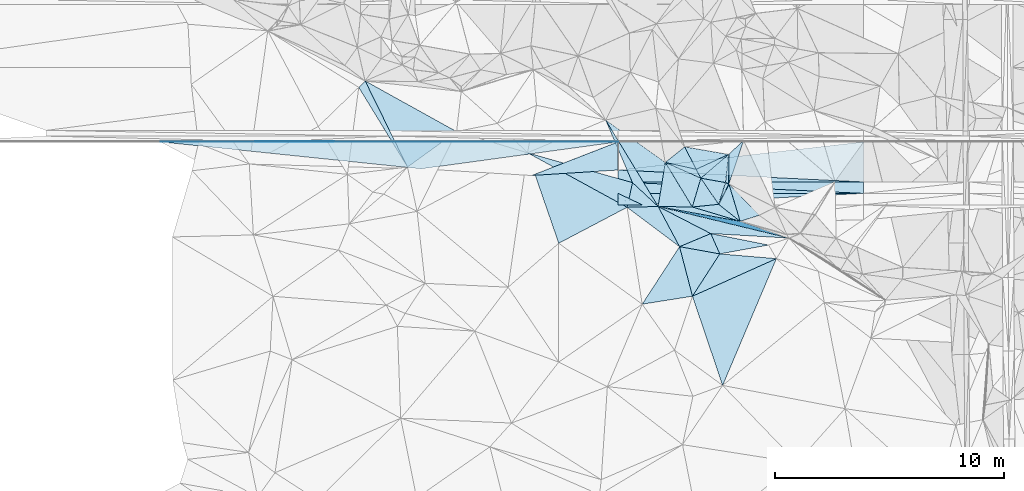
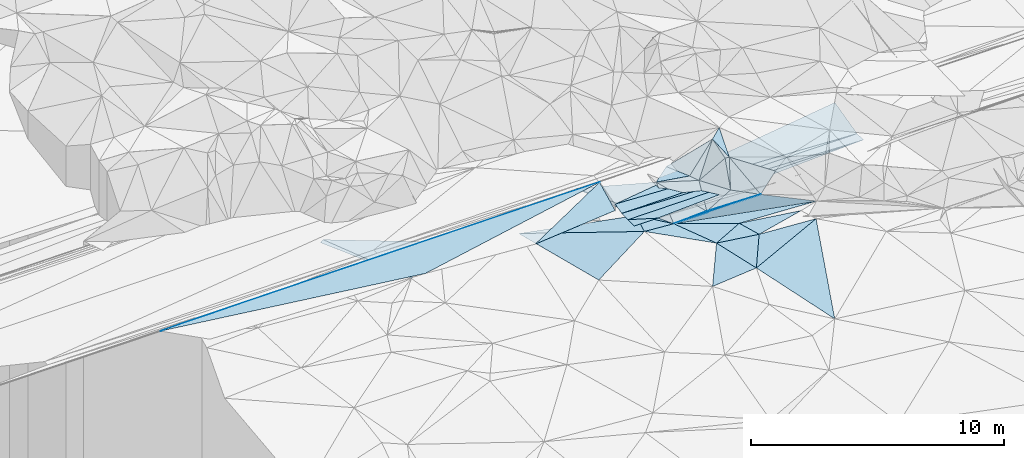
# One storey, part 47 of 275: 50 plates.
"""IFC2X3 building model written with IfcOpenShell, lengths in millimetres."""

from ifc_helpers import new_model, si_unit, frame, origin_with_axes, place, context, subcontext, project, spatial, polyline, outline, extrude, material, type_object, element, save


model = new_model("IFC2X3")

# Units and contexts
model_context = context("Model", 3, precision=1e-05, world=origin_with_axes())
body_context = subcontext(model_context, "Body", "Model", "MODEL_VIEW")
ifc_project = project(units=[si_unit("LENGTHUNIT", "METRE", prefix="MILLI"), si_unit("AREAUNIT", "SQUARE_METRE"), si_unit("VOLUMEUNIT", "CUBIC_METRE"), si_unit("MASSUNIT", "GRAM", prefix="KILO"), si_unit("TIMEUNIT", "SECOND"), si_unit("PLANEANGLEUNIT", "RADIAN"), si_unit("SOLIDANGLEUNIT", "STERADIAN"), si_unit("THERMODYNAMICTEMPERATUREUNIT", "DEGREE_CELSIUS"), si_unit("LUMINOUSINTENSITYUNIT", "LUMEN")], contexts=[model_context])

# Site, building, storey
site_placement = place(None, origin_with_axes())
site = spatial("IfcSite", under=ifc_project, at=site_placement, CompositionType="ELEMENT")
building_placement = place(site_placement, origin_with_axes())
building = spatial("IfcBuilding", under=site, at=building_placement, Name="Undefined", CompositionType="ELEMENT")
storey_placement = place(building_placement, origin_with_axes())
storey = spatial("IfcBuildingStorey", under=building, at=storey_placement, Name="Undefined", CompositionType="ELEMENT", Elevation=0.0)

# Plates
ifc_material = material()
plate_type_1 = type_object("IfcPlateType", PredefinedType="NOTDEFINED")
for number, where, z_axis, x_axis, name in (
    (1, (-135830.614985096, 60064.7002229787, 48829.0156310434), (0.00831814909004302, 0.0498972698790332, -0.998719715863432), (0.999964926595862, -0.00139059996523865, 0.00825904412565631), "00_PR"),
    (2, (-135830.614985096, 60064.7002229787, 48829.0156310434), (0.00831814909004302, 0.0498972698790332, -0.998719715863432), (0.999964926595862, -0.00139059996523865, 0.00825904412565631), "00_PR"),
    (3, (-135830.614985096, 60064.7002229787, 48829.0156310434), (0.00831814909004302, 0.0498972698790332, -0.998719715863432), (0.999964926595862, -0.00139059996523865, 0.00825904412565631), "00_PR"),
):
    element("IfcPlate", number, at=place(storey_placement, frame(where, z_axis=z_axis, x_axis=x_axis)), inside=storey, type_object=plate_type_1, material=ifc_material, Name=name, context=body_context, shape_type="SweptSolid", body=[
        extrude(outline(polyline([(0.0, 0.0), (15000.525390625, -6.48433342576027e-08), (-5000.150390625, 26.7003498077393), (0.0, 0.0)])), frame((-8.85201319254618e-08, 2.18876761149539e-07, -0.5000001331573), z_axis=(0.0, 0.0, 1.0), x_axis=(1.0, 0.0, 0.0)), (0.0, 0.0, 1.0), 1.0),
    ])
plate_type_2 = type_object("IfcPlateType", PredefinedType="NOTDEFINED")
plate_1_placement = place(storey_placement, frame((-115496.287308976, 56570.7317916144, 48609.6284639747), z_axis=(0.369579118657339, 0.557927886669343, -0.743052991602311), x_axis=(-0.782548067438589, 0.618072932079642, 0.0748623588901896)))
element("IfcPlate", 4, at=plate_1_placement, inside=storey, type_object=plate_type_2, material=ifc_material, Name="00", context=body_context, shape_type="SweptSolid", body=[
    extrude(outline(polyline([(0.0, 0.0), (1202.20629882813, -6.49015419185162e-09), (1465.638671875, 1308.62658691406), (0.0, 0.0)])), frame((-8.85201319254618e-08, 2.18876761149539e-07, -0.5000001331573), z_axis=(0.0, 0.0, 1.0), x_axis=(1.0, 0.0, 0.0)), (0.0, 0.0, 1.0), 1.0),
])
plate_type_3 = type_object("IfcPlateType", PredefinedType="NOTDEFINED")
plate_2_placement = place(storey_placement, frame((-119776.668970468, 57293.7547584565, 48524.1770099493), z_axis=(0.00832513340286068, 7.26597750999418e-06, -0.999965345450046), x_axis=(-0.903459853066548, 0.428606771995645, -0.0075185701064053)))
element("IfcPlate", 5, at=plate_2_placement, inside=storey, type_object=plate_type_3, material=ifc_material, Name="00_PR", context=body_context, shape_type="SweptSolid", body=[
    extrude(outline(polyline([(0.0, 0.0), (1166.71130371094, -6.47207798465388e-09), (-8521.5361328125, 4595.3232421875), (0.0, 0.0)])), frame((-8.85201319254618e-08, 2.18876761149539e-07, -0.5000001331573), z_axis=(0.0, 0.0, 1.0), x_axis=(1.0, 0.0, 0.0)), (0.0, 0.0, 1.0), 1.0),
])
plate_3_placement = place(storey_placement, frame((-120830.745792086, 57793.8151177411, 48515.4050098334), z_axis=(0.00832145934312362, -4.76784125253999e-07, -0.999965376057678), x_axis=(0.903459853075968, -0.428606771993251, 0.00751856911092421)))
element("IfcPlate", 6, at=plate_3_placement, inside=storey, type_object=plate_type_3, material=ifc_material, Name="00_PR", context=body_context, shape_type="SweptSolid", body=[
    extrude(outline(polyline([(0.0, 0.0), (1166.71130371094, -6.47207798465388e-09), (214.27751159668, 451.757843017578), (0.0, 0.0)])), frame((-8.85201319254618e-08, 2.18876761149539e-07, -0.5000001331573), z_axis=(0.0, 0.0, 1.0), x_axis=(1.0, 0.0, 0.0)), (0.0, 0.0, 1.0), 1.0),
])
for number, where, z_axis, x_axis, name in (
    (7, (-110108.284694637, 57793.2000674163, 48604.6740113437), (0.00832513166356312, -8.47678224280591e-06, -0.999965345454996), (-0.999965344853481, 5.72919765649429e-05, -0.00832501109232228), "00_PR"),
    (8, (-120830.717145383, 58293.8151223434, 48515.401009975), (0.00832550512650313, -4.76525014343269e-07, -0.999965342381505), (0.999965340787191, -5.73519775278889e-05, 0.0083254990906575), "00_PR"),
):
    element("IfcPlate", number, at=place(storey_placement, frame(where, z_axis=z_axis, x_axis=x_axis)), inside=storey, type_object=plate_type_3, material=ifc_material, Name=name, context=body_context, shape_type="SweptSolid", body=[
        extrude(outline(polyline([(0.0, 0.0), (10722.8330078125, 1.17288436740637e-08), (10722.8330078125, 500.0), (0.0, 0.0)])), frame((-8.85201319254618e-08, 2.18876761149539e-07, -0.5000001331573), z_axis=(0.0, 0.0, 1.0), x_axis=(1.0, 0.0, 0.0)), (0.0, 0.0, 1.0), 1.0),
    ])
for number, where, z_axis, x_axis, name in (
    (9, (-120830.745792086, 57793.8151177411, 48515.4050098334), (0.00832145934312362, -4.76784125253999e-07, -0.999965376057678), (0.903459853075968, -0.428606771993251, 0.00751856911092421), "00_PR"),
    (10, (-120830.745792086, 57793.8151177411, 48515.4050098334), (0.00832145934312362, -4.76784125253999e-07, -0.999965376057678), (0.903459853075968, -0.428606771993251, 0.00751856911092421), "00_PR"),
):
    element("IfcPlate", number, at=place(storey_placement, frame(where, z_axis=z_axis, x_axis=x_axis)), inside=storey, type_object=plate_type_3, material=ifc_material, Name=name, context=body_context, shape_type="SweptSolid", body=[
        extrude(outline(polyline([(0.0, 0.0), (1166.71130371094, -6.47207798465388e-09), (214.27751159668, 451.757843017578), (0.0, 0.0)])), frame((-8.85201319254618e-08, 2.18876761149539e-07, -0.5000001331573), z_axis=(0.0, 0.0, 1.0), x_axis=(1.0, 0.0, 0.0)), (0.0, 0.0, 1.0), 1.0),
    ])
plate_type_4 = type_object("IfcPlateType", PredefinedType="NOTDEFINED")
plate_4_placement = place(storey_placement, frame((-117420.948933111, 58846.7037948229, 48789.5661166067), z_axis=(0.431720832488177, 0.246223203070073, -0.867750688311815), x_axis=(-0.453388963247249, 0.890896965022592, 0.0272221549315876)))
element("IfcPlate", 11, at=plate_4_placement, inside=storey, type_object=plate_type_4, material=ifc_material, Name="00", context=body_context, shape_type="SweptSolid", body=[
    extrude(outline(polyline([(0.0, 0.0), (1102.04357910156, -3.63797880709171e-10), (-40.7424926757813, 1795.67260742188), (0.0, 0.0)])), frame((-8.85201319254618e-08, 2.18876761149539e-07, -0.5000001331573), z_axis=(0.0, 0.0, 1.0), x_axis=(1.0, 0.0, 0.0)), (0.0, 0.0, 1.0), 1.0),
])
plate_type_5 = type_object("IfcPlateType", PredefinedType="NOTDEFINED")
plate_5_placement = place(storey_placement, frame((-119081.786190198, 57221.0828771322, 48055.5627136048), z_axis=(0.0475193731730048, -0.482618434945434, -0.874540653957302), x_axis=(0.99790219875624, -0.0156006788333907, 0.0628316841840036)))
element("IfcPlate", 12, at=plate_5_placement, inside=storey, type_object=plate_type_5, material=ifc_material, Name="00", context=body_context, shape_type="SweptSolid", body=[
    extrude(outline(polyline([(0.0, 0.0), (1496.060546875, -9.93895810097456e-09), (3622.779296875, 678.724609375), (0.0, 0.0)])), frame((-8.85201319254618e-08, 2.18876761149539e-07, -0.5000001331573), z_axis=(0.0, 0.0, 1.0), x_axis=(1.0, 0.0, 0.0)), (0.0, 0.0, 1.0), 1.0),
])
plate_type_6 = type_object("IfcPlateType", PredefinedType="NOTDEFINED")
for number, where, z_axis, x_axis, name in (
    (13, (-124610.772724842, 58574.9100282311, 48186.809792077), (0.0074718395491489, 0.447203045414868, -0.894401256587567), (0.915882799607356, 0.355950908885779, 0.185627713035471), "00_PR"),
    (14, (-124610.772724842, 58574.9100282311, 48186.809792077), (0.0074718395491489, 0.447203045414868, -0.894401256587567), (0.915882799607356, 0.355950908885779, 0.185627713035471), "00_PR"),
    (15, (-124610.772724842, 58574.9100282311, 48186.809792077), (0.0074718395491489, 0.447203045414868, -0.894401256587567), (0.915882799607356, 0.355950908885779, 0.185627713035471), "00_PR"),
):
    element("IfcPlate", number, at=place(storey_placement, frame(where, z_axis=z_axis, x_axis=x_axis)), inside=storey, type_object=plate_type_6, material=ifc_material, Name=name, context=body_context, shape_type="SweptSolid", body=[
        extrude(outline(polyline([(0.0, 0.0), (4127.33642578125, 1.97178451344371e-08), (3575.8720703125, 1258.1845703125), (0.0, 0.0)])), frame((-8.85201319254618e-08, 2.18876761149539e-07, -0.5000001331573), z_axis=(0.0, 0.0, 1.0), x_axis=(1.0, 0.0, 0.0)), (0.0, 0.0, 1.0), 1.0),
    ])
plate_type_7 = type_object("IfcPlateType", PredefinedType="NOTDEFINED")
for number, where, z_axis, x_axis, name in (
    (16, (-120830.616385825, 60044.0391399351, 48952.9577921263), (0.0074723662007596, 0.44720202102918, -0.89440176438264), (-0.987924691395056, -0.135118973085206, -0.0758133711450937), "00_PR"),
    (17, (-120830.616385825, 60044.0391399351, 48952.9577921263), (0.0074723662007596, 0.44720202102918, -0.89440176438264), (-0.987924691395056, -0.135118973085206, -0.0758133711450937), "00_PR"),
    (18, (-120830.616385825, 60044.0391399351, 48952.9577921263), (0.0074723662007596, 0.44720202102918, -0.89440176438264), (-0.987924691395056, -0.135118973085206, -0.0758133711450937), "00_PR"),
):
    element("IfcPlate", number, at=place(storey_placement, frame(where, z_axis=z_axis, x_axis=x_axis)), inside=storey, type_object=plate_type_7, material=ifc_material, Name=name, context=body_context, shape_type="SweptSolid", body=[
        extrude(outline(polyline([(0.0, 0.0), (8719.609375, -2.08528945222497e-08), (19770.962890625, 3022.70361328125), (0.0, 0.0)])), frame((-8.85201319254618e-08, 2.18876761149539e-07, -0.5000001331573), z_axis=(0.0, 0.0, 1.0), x_axis=(1.0, 0.0, 0.0)), (0.0, 0.0, 1.0), 1.0),
    ])
plate_type_8 = type_object("IfcPlateType", PredefinedType="NOTDEFINED")
plate_6_placement = place(storey_placement, frame((-116779.892308437, 56035.932033889, 47989.5063971558), z_axis=(0.0282640599836552, 0.157148972542675, -0.98717037199362), x_axis=(0.400760479645804, -0.906502308759819, -0.132832985990617)))
element("IfcPlate", 19, at=plate_6_placement, inside=storey, type_object=plate_type_8, material=ifc_material, Name="00", context=body_context, shape_type="SweptSolid", body=[
    extrude(outline(polyline([(0.0, 0.0), (978.672546386719, 1.92085281014442e-09), (-12.4658651351929, 1485.94909667969), (0.0, 0.0)])), frame((-8.85201319254618e-08, 2.18876761149539e-07, -0.5000001331573), z_axis=(0.0, 0.0, 1.0), x_axis=(1.0, 0.0, 0.0)), (0.0, 0.0, 1.0), 1.0),
])
plate_type_9 = type_object("IfcPlateType", PredefinedType="NOTDEFINED")
plate_7_placement = place(storey_placement, frame((-110108.256159867, 58293.3213430819, 48604.688939679), z_axis=(0.00809083870061443, 0.242535022060941, -0.970108912134622), x_axis=(-0.999965344853481, 5.72919765649429e-05, -0.00832501109232228)))
element("IfcPlate", 20, at=plate_7_placement, inside=storey, type_object=plate_type_9, material=ifc_material, Name="00_PR", context=body_context, shape_type="SweptSolid", body=[
    extrude(outline(polyline([(0.0, 0.0), (10722.8330078125, 1.17288436740637e-08), (10721.748046875, 537.341918945313), (0.0, 0.0)])), frame((-8.85201319254618e-08, 2.18876761149539e-07, -0.5000001331573), z_axis=(0.0, 0.0, 1.0), x_axis=(1.0, 0.0, 0.0)), (0.0, 0.0, 1.0), 1.0),
])
plate_type_10 = type_object("IfcPlateType", PredefinedType="NOTDEFINED")
plate_8_placement = place(storey_placement, frame((-120830.687312707, 58815.2346338975, 48645.7449369341), z_axis=(0.0080904527200821, 0.242527248972756, -0.970110858655077), x_axis=(0.992835304323533, 0.113712686067626, 0.0367080851595779)))
element("IfcPlate", 21, at=plate_8_placement, inside=storey, type_object=plate_type_10, material=ifc_material, Name="00_PR", context=body_context, shape_type="SweptSolid", body=[
    extrude(outline(polyline([(0.0, 0.0), (10799.9091796875, -4.02069417759776e-08), (10584.7529296875, 1790.98132324219), (0.0, 0.0)])), frame((-8.85201319254618e-08, 2.18876761149539e-07, -0.5000001331573), z_axis=(0.0, 0.0, 1.0), x_axis=(1.0, 0.0, 0.0)), (0.0, 0.0, 1.0), 1.0),
])
plate_type_11 = type_object("IfcPlateType", PredefinedType="NOTDEFINED")
plate_9_placement = place(storey_placement, frame((-118145.677767333, 55464.8757415117, 47859.5006336671), z_axis=(-0.0449011696740856, 0.0251768616614847, -0.998674126328893), x_axis=(0.251875103580906, -0.967100851608262, -0.0357053919553195)))
element("IfcPlate", 22, at=plate_9_placement, inside=storey, type_object=plate_type_11, material=ifc_material, Name="00", context=body_context, shape_type="SweptSolid", body=[
    extrude(outline(polyline([(0.0, 0.0), (2240.55786132813, -1.46974343806505e-09), (2020.56811523438, 2215.19848632813), (0.0, 0.0)])), frame((-8.85201319254618e-08, 2.18876761149539e-07, -0.5000001331573), z_axis=(0.0, 0.0, 1.0), x_axis=(1.0, 0.0, 0.0)), (0.0, 0.0, 1.0), 1.0),
])
plate_type_12 = type_object("IfcPlateType", PredefinedType="NOTDEFINED")
plate_10_placement = place(storey_placement, frame((-116002.266986753, 59495.8079570777, 49679.5690904599), z_axis=(0.39502987458071, 0.318240899055146, -0.861785430578471), x_axis=(-0.654566115018615, -0.560705981335617, -0.507101571249686)))
element("IfcPlate", 23, at=plate_10_placement, inside=storey, type_object=plate_type_12, material=ifc_material, Name="00", context=body_context, shape_type="SweptSolid", body=[
    extrude(outline(polyline([(0.0, 0.0), (1853.67199707031, 2.5029294192791e-09), (1743.88989257813, 430.055694580078), (0.0, 0.0)])), frame((-8.85201319254618e-08, 2.18876761149539e-07, -0.5000001331573), z_axis=(0.0, 0.0, 1.0), x_axis=(1.0, 0.0, 0.0)), (0.0, 0.0, 1.0), 1.0),
])
plate_type_13 = type_object("IfcPlateType", PredefinedType="NOTDEFINED")
plate_11_placement = place(storey_placement, frame((-120437.010643785, 57185.3307943349, 48179.5030814484), z_axis=(-0.09257169403787, 0.0615576643962565, -0.993801356115515), x_axis=(0.995490997743403, 0.0264632216691322, -0.0910899078423896)))
element("IfcPlate", 24, at=plate_11_placement, inside=storey, type_object=plate_type_13, material=ifc_material, Name="00", context=body_context, shape_type="SweptSolid", body=[
    extrude(outline(polyline([(0.0, 0.0), (1361.29235839844, -1.38243194669485e-09), (2264.59790039063, 1784.37548828125), (0.0, 0.0)])), frame((-8.85201319254618e-08, 2.18876761149539e-07, -0.5000001331573), z_axis=(0.0, 0.0, 1.0), x_axis=(1.0, 0.0, 0.0)), (0.0, 0.0, 1.0), 1.0),
])
plate_type_14 = type_object("IfcPlateType", PredefinedType="NOTDEFINED")
plate_12_placement = place(storey_placement, frame((-116136.659847027, 58266.5878108403, 49549.6312453976), z_axis=(0.426882667840605, 0.523330572044719, -0.73749325438314), x_axis=(0.889623177160462, -0.389398382859552, 0.2386199951498)))
element("IfcPlate", 25, at=plate_12_placement, inside=storey, type_object=plate_type_14, material=ifc_material, Name="00", context=body_context, shape_type="SweptSolid", body=[
    extrude(outline(polyline([(0.0, 0.0), (167.63053894043, 6.18456397205591e-10), (-99.0272979736328, 1307.97314453125), (0.0, 0.0)])), frame((-8.85201319254618e-08, 2.18876761149539e-07, -0.5000001331573), z_axis=(0.0, 0.0, 1.0), x_axis=(1.0, 0.0, 0.0)), (0.0, 0.0, 1.0), 1.0),
])
plate_type_15 = type_object("IfcPlateType", PredefinedType="NOTDEFINED")
plate_13_placement = place(storey_placement, frame((-132169.328461947, 62429.2057095855, 48569.5282414469), z_axis=(-0.317153133267479, -0.0964946855527176, -0.943452524358647), x_axis=(0.675608799542987, 0.675157178374258, -0.296168084826495)))
element("IfcPlate", 26, at=plate_13_placement, inside=storey, type_object=plate_type_15, material=ifc_material, Name="00", context=body_context, shape_type="SweptSolid", body=[
    extrude(outline(polyline([(0.0, 0.0), (415.304718017578, 4.77302819490433e-09), (-806.80517578125, 4021.53759765625), (0.0, 0.0)])), frame((-8.85201319254618e-08, 2.18876761149539e-07, -0.5000001331573), z_axis=(0.0, 0.0, 1.0), x_axis=(1.0, 0.0, 0.0)), (0.0, 0.0, 1.0), 1.0),
])
plate_type_16 = type_object("IfcPlateType", PredefinedType="NOTDEFINED")
plate_14_placement = place(storey_placement, frame((-117215.51422111, 58456.2931064135, 48739.6009856864), z_axis=(0.602357626799438, 0.0185299595391645, -0.798011234279334), x_axis=(0.654566115015034, 0.560705981347095, 0.507101571241617)))
element("IfcPlate", 27, at=plate_14_placement, inside=storey, type_object=plate_type_16, material=ifc_material, Name="00", context=body_context, shape_type="SweptSolid", body=[
    extrude(outline(polyline([(0.0, 0.0), (1853.67199707031, 2.5029294192791e-09), (1010.48077392578, 913.908386230469), (0.0, 0.0)])), frame((-8.85201319254618e-08, 2.18876761149539e-07, -0.5000001331573), z_axis=(0.0, 0.0, 1.0), x_axis=(1.0, 0.0, 0.0)), (0.0, 0.0, 1.0), 1.0),
])
plate_type_17 = type_object("IfcPlateType", PredefinedType="NOTDEFINED")
plate_15_placement = place(storey_placement, frame((-115987.543498909, 58201.3298713433, 49589.6372664755), z_axis=(0.403551745914306, 0.557574890465013, -0.725435200340075), x_axis=(0.687979215344768, -0.707610294097635, -0.161159147865258)))
element("IfcPlate", 28, at=plate_15_placement, inside=storey, type_object=plate_type_17, material=ifc_material, Name="00", context=body_context, shape_type="SweptSolid", body=[
    extrude(outline(polyline([(0.0, 0.0), (1923.564453125, -1.14450813271105e-08), (1649.74975585938, 1067.20458984375), (0.0, 0.0)])), frame((-8.85201319254618e-08, 2.18876761149539e-07, -0.5000001331573), z_axis=(0.0, 0.0, 1.0), x_axis=(1.0, 0.0, 0.0)), (0.0, 0.0, 1.0), 1.0),
])
plate_type_18 = type_object("IfcPlateType", PredefinedType="NOTDEFINED")
plate_16_placement = place(storey_placement, frame((-116387.671054048, 55148.7664768484, 47859.5072283944), z_axis=(0.0441410186254733, 0.163921193080716, -0.985485369213415), x_axis=(-0.400760479635588, 0.9065023087724, 0.132832985935581)))
element("IfcPlate", 29, at=plate_16_placement, inside=storey, type_object=plate_type_18, material=ifc_material, Name="00", context=body_context, shape_type="SweptSolid", body=[
    extrude(outline(polyline([(0.0, 0.0), (978.672546386719, 1.92085281014442e-09), (-484.227325439453, 2122.10375976563), (0.0, 0.0)])), frame((-8.85201319254618e-08, 2.18876761149539e-07, -0.5000001331573), z_axis=(0.0, 0.0, 1.0), x_axis=(1.0, 0.0, 0.0)), (0.0, 0.0, 1.0), 1.0),
])
plate_type_19 = type_object("IfcPlateType", PredefinedType="NOTDEFINED")
plate_17_placement = place(storey_placement, frame((-118145.635659057, 55464.9288958938, 47859.504701647), z_axis=(0.0393139198775856, 0.131485636948031, -0.990538208743221), x_axis=(-0.468079857684008, 0.878235243855961, 0.0980005269362342)))
element("IfcPlate", 30, at=plate_17_placement, inside=storey, type_object=plate_type_19, material=ifc_material, Name="00", context=body_context, shape_type="SweptSolid", body=[
    extrude(outline(polyline([(0.0, 0.0), (1999.9892578125, -8.71659722179174e-09), (-125.075675964355, 1480.72827148438), (0.0, 0.0)])), frame((-8.85201319254618e-08, 2.18876761149539e-07, -0.5000001331573), z_axis=(0.0, 0.0, 1.0), x_axis=(1.0, 0.0, 0.0)), (0.0, 0.0, 1.0), 1.0),
])
plate_type_20 = type_object("IfcPlateType", PredefinedType="NOTDEFINED")
plate_18_placement = place(storey_placement, frame((-117215.795197694, 58456.3577652648, 48739.5058996514), z_axis=(0.0403983651372587, 0.147849020110908, -0.988184516852233), x_axis=(-0.91320437258695, 0.406821718584614, 0.0235342978636645)))
element("IfcPlate", 31, at=plate_18_placement, inside=storey, type_object=plate_type_20, material=ifc_material, Name="00", context=body_context, shape_type="SweptSolid", body=[
    extrude(outline(polyline([(0.0, 0.0), (1699.64697265625, -8.90213414095342e-09), (347.483917236328, 276.142944335938), (0.0, 0.0)])), frame((-8.85201319254618e-08, 2.18876761149539e-07, -0.5000001331573), z_axis=(0.0, 0.0, 1.0), x_axis=(1.0, 0.0, 0.0)), (0.0, 0.0, 1.0), 1.0),
])
plate_type_21 = type_object("IfcPlateType", PredefinedType="NOTDEFINED")
plate_19_placement = place(storey_placement, frame((-116002.321107045, 59495.6836781537, 49679.5222625761), z_axis=(0.286780182758937, 0.0696837789164654, -0.955458684471847), x_axis=(0.011341625215273, -0.997528068826549, -0.0693478149666773)))
element("IfcPlate", 32, at=plate_19_placement, inside=storey, type_object=plate_type_21, material=ifc_material, Name="00", context=body_context, shape_type="SweptSolid", body=[
    extrude(outline(polyline([(0.0, 0.0), (1297.80578613281, -9.02218744158745e-10), (1233.77465820313, 154.919372558594), (0.0, 0.0)])), frame((-8.85201319254618e-08, 2.18876761149539e-07, -0.5000001331573), z_axis=(0.0, 0.0, 1.0), x_axis=(1.0, 0.0, 0.0)), (0.0, 0.0, 1.0), 1.0),
])
plate_type_22 = type_object("IfcPlateType", PredefinedType="NOTDEFINED")
plate_20_placement = place(storey_placement, frame((-115987.806377234, 58201.0848073332, 49589.5048871619), z_axis=(-0.122213837797875, 0.0674494753066479, -0.990209243610446), x_axis=(-0.0113416252167756, 0.997528068757604, 0.0693478159581554)))
element("IfcPlate", 33, at=plate_20_placement, inside=storey, type_object=plate_type_22, material=ifc_material, Name="00", context=body_context, shape_type="SweptSolid", body=[
    extrude(outline(polyline([(0.0, 0.0), (1297.80578613281, -9.02218744158745e-10), (1894.96752929688, 672.010314941406), (0.0, 0.0)])), frame((-8.85201319254618e-08, 2.18876761149539e-07, -0.5000001331573), z_axis=(0.0, 0.0, 1.0), x_axis=(1.0, 0.0, 0.0)), (0.0, 0.0, 1.0), 1.0),
])
plate_type_23 = type_object("IfcPlateType", PredefinedType="NOTDEFINED")
plate_21_placement = place(storey_placement, frame((-116436.961339623, 57313.7169726025, 48699.6570170575), z_axis=(0.589957034554261, 0.425938900220367, -0.68594952486244), x_axis=(-0.562800722178987, 0.826086720880697, 0.0289149909110858)))
element("IfcPlate", 34, at=plate_21_placement, inside=storey, type_object=plate_type_23, material=ifc_material, Name="00", context=body_context, shape_type="SweptSolid", body=[
    extrude(outline(polyline([(0.0, 0.0), (1383.36547851563, 2.66300048679113e-09), (642.635681152344, 1143.51184082031), (0.0, 0.0)])), frame((-8.85201319254618e-08, 2.18876761149539e-07, -0.5000001331573), z_axis=(0.0, 0.0, 1.0), x_axis=(1.0, 0.0, 0.0)), (0.0, 0.0, 1.0), 1.0),
])
plate_type_24 = type_object("IfcPlateType", PredefinedType="NOTDEFINED")
plate_22_placement = place(storey_placement, frame((-117215.741675934, 58456.4757017853, 48739.5441906565), z_axis=(0.147449970454932, 0.383720556535655, -0.911601360631283), x_axis=(-0.25926573382735, -0.874451689349122, -0.410018929145268)))
element("IfcPlate", 35, at=plate_22_placement, inside=storey, type_object=plate_type_24, material=ifc_material, Name="00", context=body_context, shape_type="SweptSolid", body=[
    extrude(outline(polyline([(0.0, 0.0), (1438.9580078125, 5.96628524363041e-09), (-218.630432128906, 1685.52685546875), (0.0, 0.0)])), frame((-8.85201319254618e-08, 2.18876761149539e-07, -0.5000001331573), z_axis=(0.0, 0.0, 1.0), x_axis=(1.0, 0.0, 0.0)), (0.0, 0.0, 1.0), 1.0),
])
plate_type_25 = type_object("IfcPlateType", PredefinedType="NOTDEFINED")
plate_23_placement = place(storey_placement, frame((-119081.626354986, 57221.4612918529, 48055.5555857234), z_axis=(0.367180894216145, 0.274215321150333, -0.888810524560242), x_axis=(-0.518404252243932, 0.853717542959993, 0.0492279199008323)))
element("IfcPlate", 36, at=plate_23_placement, inside=storey, type_object=plate_type_25, material=ifc_material, Name="00", context=body_context, shape_type="SweptSolid", body=[
    extrude(outline(polyline([(0.0, 0.0), (4428.38134765625, 9.80071490630507e-09), (1517.54235839844, 1425.06921386719), (0.0, 0.0)])), frame((-8.85201319254618e-08, 2.18876761149539e-07, -0.5000001331573), z_axis=(0.0, 0.0, 1.0), x_axis=(1.0, 0.0, 0.0)), (0.0, 0.0, 1.0), 1.0),
])
plate_type_26 = type_object("IfcPlateType", PredefinedType="NOTDEFINED")
plate_24_placement = place(storey_placement, frame((-116437.062520853, 57313.6513234433, 48699.5632542136), z_axis=(0.387600438391242, 0.294640056863977, -0.873471886811539), x_axis=(-0.89869797129302, -0.0901477812315407, -0.429203138307306)))
element("IfcPlate", 37, at=plate_24_placement, inside=storey, type_object=plate_type_26, material=ifc_material, Name="00", context=body_context, shape_type="SweptSolid", body=[
    extrude(outline(polyline([(0.0, 0.0), (1281.44445800781, -2.19733919948339e-09), (579.502258300781, 1256.1357421875), (0.0, 0.0)])), frame((-8.85201319254618e-08, 2.18876761149539e-07, -0.5000001331573), z_axis=(0.0, 0.0, 1.0), x_axis=(1.0, 0.0, 0.0)), (0.0, 0.0, 1.0), 1.0),
])
plate_type_27 = type_object("IfcPlateType", PredefinedType="NOTDEFINED")
plate_25_placement = place(storey_placement, frame((-115496.308100146, 56570.7085722303, 48609.6028712755), z_axis=(0.328002708686716, 0.511485894838055, -0.794226921273695), x_axis=(-0.937295215871749, 0.281102137797462, -0.206056464178217)))
element("IfcPlate", 38, at=plate_25_placement, inside=storey, type_object=plate_type_27, material=ifc_material, Name="00", context=body_context, shape_type="SweptSolid", body=[
    extrude(outline(polyline([(0.0, 0.0), (2232.39770507813, -6.34463503956795e-09), (1072.12072753906, 543.927490234375), (0.0, 0.0)])), frame((-8.85201319254618e-08, 2.18876761149539e-07, -0.5000001331573), z_axis=(0.0, 0.0, 1.0), x_axis=(1.0, 0.0, 0.0)), (0.0, 0.0, 1.0), 1.0),
])
plate_type_28 = type_object("IfcPlateType", PredefinedType="NOTDEFINED")
plate_26_placement = place(storey_placement, frame((-115496.363234401, 56570.9120949491, 48609.8349907829), z_axis=(0.217736431081698, 0.918530822915817, -0.329987839068952), x_axis=(0.911597596902385, -0.312179040807322, -0.26745853473467)))
element("IfcPlate", 39, at=plate_26_placement, inside=storey, type_object=plate_type_28, material=ifc_material, Name="00", context=body_context, shape_type="SweptSolid", body=[
    extrude(outline(polyline([(0.0, 0.0), (2340.5498046875, -7.76708475314081e-09), (-3323.40161132813, 1593.7998046875), (0.0, 0.0)])), frame((-8.85201319254618e-08, 2.18876761149539e-07, -0.5000001331573), z_axis=(0.0, 0.0, 1.0), x_axis=(1.0, 0.0, 0.0)), (0.0, 0.0, 1.0), 1.0),
])
plate_type_29 = type_object("IfcPlateType", PredefinedType="NOTDEFINED")
plate_27_placement = place(storey_placement, frame((-117588.855705687, 57198.1555599505, 48149.5312135133), z_axis=(0.0643756814502861, 0.341865604781831, -0.937541295039832), x_axis=(-0.99790219875613, 0.0156006788355372, -0.0628316841852219)))
element("IfcPlate", 40, at=plate_27_placement, inside=storey, type_object=plate_type_29, material=ifc_material, Name="00", context=body_context, shape_type="SweptSolid", body=[
    extrude(outline(polyline([(0.0, 0.0), (1496.060546875, -9.93895810097456e-09), (1167.41271972656, 2055.66235351563), (0.0, 0.0)])), frame((-8.85201319254618e-08, 2.18876761149539e-07, -0.5000001331573), z_axis=(0.0, 0.0, 1.0), x_axis=(1.0, 0.0, 0.0)), (0.0, 0.0, 1.0), 1.0),
])
plate_type_30 = type_object("IfcPlateType", PredefinedType="NOTDEFINED")
plate_28_placement = place(storey_placement, frame((-118767.932456803, 59147.7565194236, 48779.5004226637), z_axis=(0.0160745853066211, 0.0387096069696881, -0.999121200873784), x_axis=(0.779013587745515, 0.62592712401226, 0.0367840391148468)))
element("IfcPlate", 41, at=plate_28_placement, inside=storey, type_object=plate_type_30, material=ifc_material, Name="00", context=body_context, shape_type="SweptSolid", body=[
    extrude(outline(polyline([(0.0, 0.0), (1087.42810058594, -8.44011083245277e-10), (861.022399902344, 1078.53625488281), (0.0, 0.0)])), frame((-8.85201319254618e-08, 2.18876761149539e-07, -0.5000001331573), z_axis=(0.0, 0.0, 1.0), x_axis=(1.0, 0.0, 0.0)), (0.0, 0.0, 1.0), 1.0),
])
plate_type_31 = type_object("IfcPlateType", PredefinedType="NOTDEFINED")
plate_29_placement = place(storey_placement, frame((-118145.651844006, 55464.8825047143, 47859.5003569703), z_axis=(0.00696120017061092, 0.0387044692479552, -0.999226453689262), x_axis=(0.98420816207541, -0.177014953334865, 2.0813949439734e-10)))
element("IfcPlate", 42, at=plate_29_placement, inside=storey, type_object=plate_type_31, material=ifc_material, Name="00", context=body_context, shape_type="SweptSolid", body=[
    extrude(outline(polyline([(0.0, 0.0), (1786.16906738281, -1.18816387839615e-08), (938.992858886719, 2034.30395507813), (0.0, 0.0)])), frame((-8.85201319254618e-08, 2.18876761149539e-07, -0.5000001331573), z_axis=(0.0, 0.0, 1.0), x_axis=(1.0, 0.0, 0.0)), (0.0, 0.0, 1.0), 1.0),
])
plate_type_32 = type_object("IfcPlateType", PredefinedType="NOTDEFINED")
plate_30_placement = place(storey_placement, frame((-120202.326623664, 58262.1357214258, 48209.5001920948), z_axis=(0.0177122682515786, 0.0239880029544469, -0.999555326766679), x_axis=(-0.212815833268862, -0.976713358713841, -0.0272109540444334)))
element("IfcPlate", 43, at=plate_30_placement, inside=storey, type_object=plate_type_32, material=ifc_material, Name="00", context=body_context, shape_type="SweptSolid", body=[
    extrude(outline(polyline([(0.0, 0.0), (1102.49719238281, 4.65661287307739e-10), (-297.052917480469, 4762.9462890625), (0.0, 0.0)])), frame((-8.85201319254618e-08, 2.18876761149539e-07, -0.5000001331573), z_axis=(0.0, 0.0, 1.0), x_axis=(1.0, 0.0, 0.0)), (0.0, 0.0, 1.0), 1.0),
])
plate_type_33 = type_object("IfcPlateType", PredefinedType="NOTDEFINED")
plate_31_placement = place(storey_placement, frame((-121377.596042518, 61001.8820082351, 48273.5098111072), z_axis=(-0.18860379677119, -0.0579968755404049, -0.980339211839985), x_axis=(0.518404252658382, -0.853717542705582, -0.0492279199484097)))
element("IfcPlate", 44, at=plate_31_placement, inside=storey, type_object=plate_type_33, material=ifc_material, Name="00", context=body_context, shape_type="SweptSolid", body=[
    extrude(outline(polyline([(0.0, 0.0), (4428.38134765625, 9.80071490630507e-09), (2951.3662109375, 425.421478271484), (0.0, 0.0)])), frame((-8.85201319254618e-08, 2.18876761149539e-07, -0.5000001331573), z_axis=(0.0, 0.0, 1.0), x_axis=(1.0, 0.0, 0.0)), (0.0, 0.0, 1.0), 1.0),
])
plate_type_34 = type_object("IfcPlateType", PredefinedType="NOTDEFINED")
plate_32_placement = place(storey_placement, frame((-119081.809232152, 57221.3535568272, 48055.5008448445), z_axis=(0.00161628153167494, 0.0587163952021233, -0.99827339570304), x_axis=(0.971966804084993, -0.234799476313405, -0.0122367348485961)))
element("IfcPlate", 45, at=plate_32_placement, inside=storey, type_object=plate_type_34, material=ifc_material, Name="00", context=body_context, shape_type="SweptSolid", body=[
    extrude(outline(polyline([(0.0, 0.0), (5883.92236328125, -9.33869159780443e-09), (2516.529296875, 612.810546875), (0.0, 0.0)])), frame((-8.85201319254618e-08, 2.18876761149539e-07, -0.5000001331573), z_axis=(0.0, 0.0, 1.0), x_axis=(1.0, 0.0, 0.0)), (0.0, 0.0, 1.0), 1.0),
])
plate_type_35 = type_object("IfcPlateType", PredefinedType="NOTDEFINED")
plate_33_placement = place(storey_placement, frame((-119081.856141956, 57221.3481081001, 48055.5026777783), z_axis=(-0.0922780448238293, 0.0478152819126279, -0.994584567173203), x_axis=(-0.995490997749292, -0.026463221642808, 0.0910899077856729)))
element("IfcPlate", 46, at=plate_33_placement, inside=storey, type_object=plate_type_35, material=ifc_material, Name="00", context=body_context, shape_type="SweptSolid", body=[
    extrude(outline(polyline([(0.0, 0.0), (1361.29235839844, -1.38243194669485e-09), (1101.9580078125, 1071.56225585938), (0.0, 0.0)])), frame((-8.85201319254618e-08, 2.18876761149539e-07, -0.5000001331573), z_axis=(0.0, 0.0, 1.0), x_axis=(1.0, 0.0, 0.0)), (0.0, 0.0, 1.0), 1.0),
])
plate_type_36 = type_object("IfcPlateType", PredefinedType="NOTDEFINED")
plate_34_placement = place(storey_placement, frame((-117581.310917194, 53298.036893331, 47779.5003548906), z_axis=(0.00725707706901966, 0.038513865180318, -0.999231713378477), x_axis=(0.541655046547613, 0.839816575517357, 0.0363033061277062)))
element("IfcPlate", 47, at=plate_34_placement, inside=storey, type_object=plate_type_36, material=ifc_material, Name="00", context=body_context, shape_type="SweptSolid", body=[
    extrude(outline(polyline([(0.0, 0.0), (2203.65600585938, -7.11588654667139e-09), (3370.85278320313, 2192.31665039063), (0.0, 0.0)])), frame((-8.85201319254618e-08, 2.18876761149539e-07, -0.5000001331573), z_axis=(0.0, 0.0, 1.0), x_axis=(1.0, 0.0, 0.0)), (0.0, 0.0, 1.0), 1.0),
])
plate_type_37 = type_object("IfcPlateType", PredefinedType="NOTDEFINED")
plate_35_placement = place(storey_placement, frame((-116261.927087933, 49398.5854196827, 47229.5043978188), z_axis=(-0.0332762351354879, 0.128536009436793, -0.99114640011114), x_axis=(-0.317680699686476, 0.938904750932615, 0.132426740965997)))
element("IfcPlate", 48, at=plate_35_placement, inside=storey, type_object=plate_type_37, material=ifc_material, Name="00", context=body_context, shape_type="SweptSolid", body=[
    extrude(outline(polyline([(0.0, 0.0), (4153.23974609375, 9.56060830503702e-09), (4543.03173828125, 4002.11962890625), (0.0, 0.0)])), frame((-8.85201319254618e-08, 2.18876761149539e-07, -0.5000001331573), z_axis=(0.0, 0.0, 1.0), x_axis=(1.0, 0.0, 0.0)), (0.0, 0.0, 1.0), 1.0),
])
plate_type_38 = type_object("IfcPlateType", PredefinedType="NOTDEFINED")
plate_36_placement = place(storey_placement, frame((-127891.251642683, 60493.7534377881, 48279.5008501957), z_axis=(-0.00945847978125228, 0.0581702653860634, -0.998261868141392), x_axis=(-0.810382697702355, -0.585304561621644, -0.0264282691364641)))
element("IfcPlate", 49, at=plate_36_placement, inside=storey, type_object=plate_type_38, material=ifc_material, Name="00", context=body_context, shape_type="SweptSolid", body=[
    extrude(outline(polyline([(0.0, 0.0), (2648.67895507813, -3.21597326546907e-09), (1937.96984863281, 4142.609375), (0.0, 0.0)])), frame((-8.85201319254618e-08, 2.18876761149539e-07, -0.5000001331573), z_axis=(0.0, 0.0, 1.0), x_axis=(1.0, 0.0, 0.0)), (0.0, 0.0, 1.0), 1.0),
])
plate_type_39 = type_object("IfcPlateType", PredefinedType="NOTDEFINED")
plate_37_placement = place(storey_placement, frame((-124792.161843723, 59567.7850628745, 48159.5034377855), z_axis=(0.0598086806962052, 0.100996964354667, -0.993087375261876), x_axis=(0.877307233830901, -0.479912269691387, 0.0040287550974252)))
element("IfcPlate", 50, at=plate_37_placement, inside=storey, type_object=plate_type_39, material=ifc_material, Name="00", context=body_context, shape_type="SweptSolid", body=[
    extrude(outline(polyline([(0.0, 0.0), (4964.3125, -2.36832420341671e-09), (3095.373046875, 2834.16040039063), (0.0, 0.0)])), frame((-8.85201319254618e-08, 2.18876761149539e-07, -0.5000001331573), z_axis=(0.0, 0.0, 1.0), x_axis=(1.0, 0.0, 0.0)), (0.0, 0.0, 1.0), 1.0),
])

save(model, "model.ifc")
